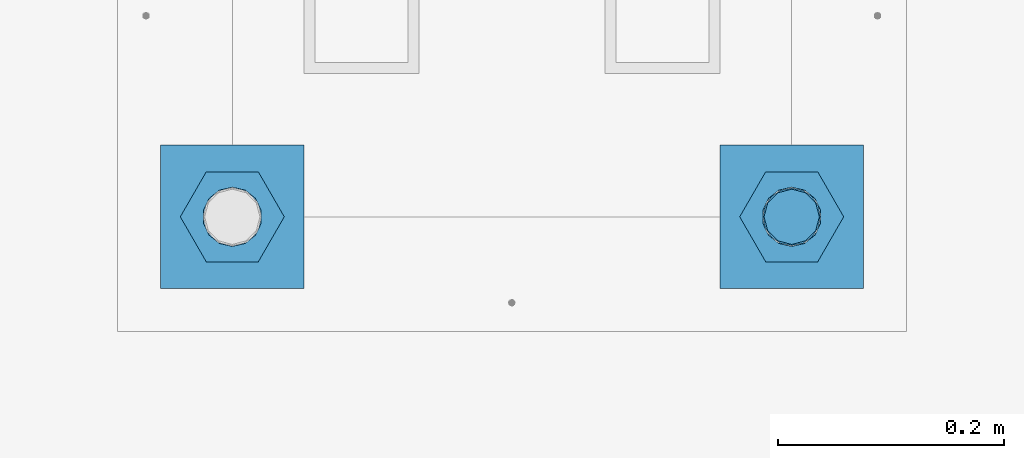
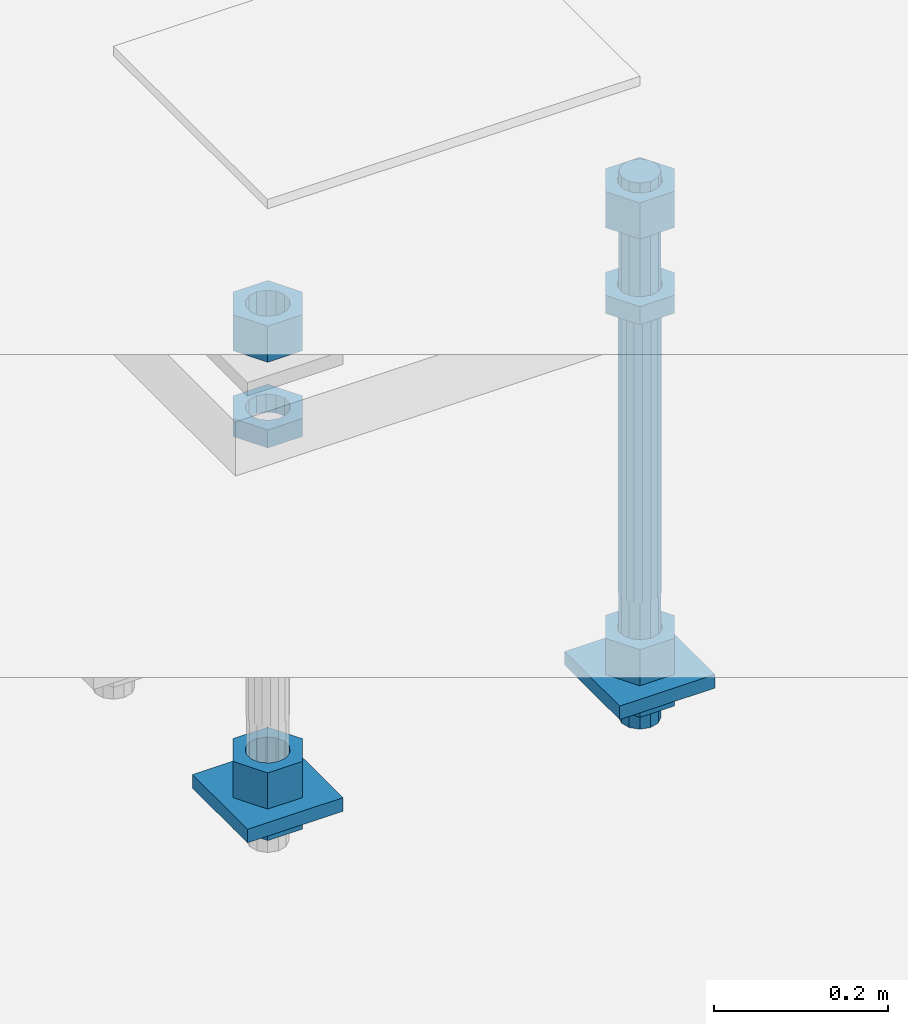
# One storey, part 2594 of 3843: 11 beams, 1 element without a shape of its own.
"""IFC2X3 building model written with IfcOpenShell, lengths in millimetres."""

from ifc_helpers import new_model, si_unit, frame, origin_with_axes, place, context, subcontext, project, spatial, faceted_brep, material, type_object, element, aggregate, save


model = new_model("IFC2X3")

# Units and contexts
model_context = context("Model", 3, precision=1e-05, world=origin_with_axes())
body_context = subcontext(model_context, "Body", "Model", "MODEL_VIEW")
ifc_project = project(units=[si_unit("LENGTHUNIT", "METRE", prefix="MILLI"), si_unit("AREAUNIT", "SQUARE_METRE"), si_unit("VOLUMEUNIT", "CUBIC_METRE"), si_unit("MASSUNIT", "GRAM", prefix="KILO"), si_unit("TIMEUNIT", "SECOND"), si_unit("PLANEANGLEUNIT", "RADIAN"), si_unit("SOLIDANGLEUNIT", "STERADIAN"), si_unit("THERMODYNAMICTEMPERATUREUNIT", "DEGREE_CELSIUS"), si_unit("LUMINOUSINTENSITYUNIT", "LUMEN")], contexts=[model_context])

# Site, building, storey
site_placement = place(None, origin_with_axes())
site = spatial("IfcSite", under=ifc_project, at=site_placement, CompositionType="ELEMENT")
building_placement = place(site_placement, origin_with_axes())
building = spatial("IfcBuilding", under=site, at=building_placement, Name="Undefined", CompositionType="ELEMENT")
storey_placement = place(building_placement, origin_with_axes())
storey = spatial("IfcBuildingStorey", under=building, at=storey_placement, Name="Undefined", CompositionType="ELEMENT", Elevation=0.0)

# Assembly, beams
assembly_placement = place(storey_placement, origin_with_axes())
assembly = element("IfcElementAssembly", 1, at=assembly_placement, inside=storey, Name="TEMPLATE", AssemblyPlace="NOTDEFINED", PredefinedType="RIGID_FRAME")
ifc_material_1 = material(Name="STEEL/A572-50")
beam_type_1 = type_object("IfcBeamType", PredefinedType="NOTDEFINED")
beam_1_placement = place(assembly_placement, frame((105403.65, 17602.1999984741, 29244.925), z_axis=(-1.0, 0.0, 0.0), x_axis=(0.0, -1.0, 0.0)))
beam_1 = element("IfcBeam", 2, at=beam_1_placement, type_object=beam_type_1, material=ifc_material_1, Name="WASHER_PLATE", context=body_context, shape_type="Brep", body=[
    faceted_brep([(0.0, 9.52500000000146, -63.5), (0.0, 9.52500000000146, 63.5), (127.0, 9.52500000000146, 63.5), (127.0, 9.52500000000146, -63.5), (0.0, -9.52500000000146, 63.5), (127.0, -9.52500000000146, 63.5), (0.0, -9.52500000000146, -63.5), (127.0, -9.52500000000146, -63.5)], [[[0, 1, 2, 3]], [[1, 4, 5, 2]], [[4, 6, 7, 5]], [[6, 0, 3, 7]], [[5, 7, 3, 2]], [[6, 4, 1, 0]]]),
])
beam_2_placement = place(assembly_placement, frame((104908.35, 17602.1999984741, 29244.925), z_axis=(-1.0, 0.0, 0.0), x_axis=(0.0, -1.0, 0.0)))
beam_2 = element("IfcBeam", 3, at=beam_2_placement, type_object=beam_type_1, material=ifc_material_1, Name="WASHER_PLATE", context=body_context, shape_type="Brep", body=[
    faceted_brep([(0.0, 9.52500000000146, -63.5), (0.0, 9.52500000000146, 63.5), (127.0, 9.52500000000146, 63.5), (127.0, 9.52500000000146, -63.5), (0.0, -9.52500000000146, 63.5), (127.0, -9.52500000000146, 63.5), (0.0, -9.52500000000146, -63.5), (127.0, -9.52500000000146, -63.5)], [[[0, 1, 2, 3]], [[1, 4, 5, 2]], [[4, 6, 7, 5]], [[6, 0, 3, 7]], [[5, 7, 3, 2]], [[6, 4, 1, 0]]]),
])
ifc_material_2 = material(Name="STEEL/A36")
beam_type_2 = type_object("IfcBeamType", Name="2_HALF_NUT", PredefinedType="NOTDEFINED")
beam_3_placement = place(assembly_placement, frame((105403.65, 17538.6999984741, 29787.85), z_axis=(0.0, -1.0, 0.0), x_axis=(0.0, 0.0, -1.0)))
beam_3 = element("IfcBeam", 4, at=beam_3_placement, type_object=beam_type_2, material=ifc_material_2, Name="NUT", ObjectType="2_HALF_NUT", context=body_context, shape_type="Brep", body=[
    faceted_brep([(0.0, -46.0369987487793, 0.0), (0.0, -23.0184993743896, -39.869213104248), (25.4000000000015, -23.0184993743896, -39.869213104248), (25.4000000000015, -46.0369987487793, 0.0), (0.0, 23.0184993743896, -39.869213104248), (25.4000000000015, 23.0184993743896, -39.869213104248), (0.0, 46.0369987487793, 0.0), (25.4000000000015, 46.0369987487793, 0.0), (0.0, 23.0184993743896, 39.869213104248), (25.4000000000015, 23.0184993743896, 39.869213104248), (0.0, -23.0184993743896, 39.869213104248), (25.4000000000015, -23.0184993743896, 39.869213104248), (0.0, 0.0, 26.1940002441406), (0.0, 11.3650617044477, 23.5999013092805), (25.4000000000015, 11.3650617044477, 23.5999013092805), (25.4000000000015, 0.0, 26.1940002441406), (0.0, 20.4791109456419, 16.3316083006721), (25.4000000000015, 20.4791109456419, 16.3316083006721), (0.0, 25.5370200498292, 5.82867859874386), (25.4000000000015, 25.5370200498292, 5.82867859874386), (0.0, 25.5370200498292, -5.82867859874386), (25.4000000000015, 25.5370200498292, -5.82867859874386), (0.0, 20.4791109456419, -16.3316083006721), (25.4000000000015, 20.4791109456419, -16.3316083006721), (0.0, 11.3650617044477, -23.5999013092805), (25.4000000000015, 11.3650617044477, -23.5999013092805), (0.0, 0.0, -26.1940002441406), (25.4000000000015, 0.0, -26.1940002441406), (0.0, -11.3650617044477, -23.5999013092805), (25.4000000000015, -11.3650617044477, -23.5999013092805), (0.0, -20.4791109456419, -16.3316083006721), (25.4000000000015, -20.4791109456419, -16.3316083006721), (0.0, -25.5370200498292, -5.82867859874386), (25.4000000000015, -25.5370200498292, -5.82867859874386), (0.0, -25.5370200498292, 5.82867859874386), (25.4000000000015, -25.5370200498292, 5.82867859874386), (0.0, -20.4791109456419, 16.3316083006721), (25.4000000000015, -20.4791109456419, 16.3316083006721), (0.0, -11.3650617044477, 23.5999013092805), (25.4000000000015, -11.3650617044477, 23.5999013092805)], [[[0, 1, 2, 3]], [[1, 4, 5, 2]], [[4, 6, 7, 5]], [[6, 8, 9, 7]], [[8, 10, 11, 9]], [[10, 0, 3, 11]], [[12, 13, 14, 15]], [[13, 16, 17, 14]], [[16, 18, 19, 17]], [[18, 20, 21, 19]], [[20, 22, 23, 21]], [[22, 24, 25, 23]], [[24, 26, 27, 25]], [[26, 28, 29, 27]], [[28, 30, 31, 29]], [[30, 32, 33, 31]], [[32, 34, 35, 33]], [[34, 36, 37, 35]], [[36, 38, 39, 37]], [[38, 12, 15, 39]], [[5, 7, 9, 11, 3, 2], [17, 19, 21, 23, 25, 27, 29, 31, 33, 35, 37, 39, 15, 14]], [[10, 8, 6, 4, 1, 0], [38, 36, 34, 32, 30, 28, 26, 24, 22, 20, 18, 16, 13, 12]]]),
])
beam_4_placement = place(assembly_placement, frame((105403.65, 17538.6999984741, 29235.4), z_axis=(0.0, -1.0, 0.0), x_axis=(0.0, 0.0, -1.0)))
beam_4 = element("IfcBeam", 5, at=beam_4_placement, type_object=beam_type_2, material=ifc_material_2, Name="NUT", ObjectType="2_HALF_NUT", context=body_context, shape_type="Brep", body=[
    faceted_brep([(0.0, -46.0369987487793, 0.0), (0.0, -23.0184993743896, -39.869213104248), (25.4000000000015, -23.0184993743896, -39.869213104248), (25.4000000000015, -46.0369987487793, 0.0), (0.0, 23.0184993743896, -39.869213104248), (25.4000000000015, 23.0184993743896, -39.869213104248), (0.0, 46.0369987487793, 0.0), (25.4000000000015, 46.0369987487793, 0.0), (0.0, 23.0184993743896, 39.869213104248), (25.4000000000015, 23.0184993743896, 39.869213104248), (0.0, -23.0184993743896, 39.869213104248), (25.4000000000015, -23.0184993743896, 39.869213104248), (0.0, 0.0, 26.1940002441406), (0.0, 11.3650617044477, 23.5999013092805), (25.4000000000015, 11.3650617044477, 23.5999013092805), (25.4000000000015, 0.0, 26.1940002441406), (0.0, 20.4791109456419, 16.3316083006721), (25.4000000000015, 20.4791109456419, 16.3316083006721), (0.0, 25.5370200498292, 5.82867859874386), (25.4000000000015, 25.5370200498292, 5.82867859874386), (0.0, 25.5370200498292, -5.82867859874386), (25.4000000000015, 25.5370200498292, -5.82867859874386), (0.0, 20.4791109456419, -16.3316083006721), (25.4000000000015, 20.4791109456419, -16.3316083006721), (0.0, 11.3650617044477, -23.5999013092805), (25.4000000000015, 11.3650617044477, -23.5999013092805), (0.0, 0.0, -26.1940002441406), (25.4000000000015, 0.0, -26.1940002441406), (0.0, -11.3650617044477, -23.5999013092805), (25.4000000000015, -11.3650617044477, -23.5999013092805), (0.0, -20.4791109456419, -16.3316083006721), (25.4000000000015, -20.4791109456419, -16.3316083006721), (0.0, -25.5370200498292, -5.82867859874386), (25.4000000000015, -25.5370200498292, -5.82867859874386), (0.0, -25.5370200498292, 5.82867859874386), (25.4000000000015, -25.5370200498292, 5.82867859874386), (0.0, -20.4791109456419, 16.3316083006721), (25.4000000000015, -20.4791109456419, 16.3316083006721), (0.0, -11.3650617044477, 23.5999013092805), (25.4000000000015, -11.3650617044477, 23.5999013092805)], [[[0, 1, 2, 3]], [[1, 4, 5, 2]], [[4, 6, 7, 5]], [[6, 8, 9, 7]], [[8, 10, 11, 9]], [[10, 0, 3, 11]], [[12, 13, 14, 15]], [[13, 16, 17, 14]], [[16, 18, 19, 17]], [[18, 20, 21, 19]], [[20, 22, 23, 21]], [[22, 24, 25, 23]], [[24, 26, 27, 25]], [[26, 28, 29, 27]], [[28, 30, 31, 29]], [[30, 32, 33, 31]], [[32, 34, 35, 33]], [[34, 36, 37, 35]], [[36, 38, 39, 37]], [[38, 12, 15, 39]], [[5, 7, 9, 11, 3, 2], [17, 19, 21, 23, 25, 27, 29, 31, 33, 35, 37, 39, 15, 14]], [[10, 8, 6, 4, 1, 0], [38, 36, 34, 32, 30, 28, 26, 24, 22, 20, 18, 16, 13, 12]]]),
])
beam_5_placement = place(assembly_placement, frame((104908.35, 17538.6999984741, 29787.85), z_axis=(0.0, -1.0, 0.0), x_axis=(0.0, 0.0, -1.0)))
beam_5 = element("IfcBeam", 6, at=beam_5_placement, type_object=beam_type_2, material=ifc_material_2, Name="NUT", ObjectType="2_HALF_NUT", context=body_context, shape_type="Brep", body=[
    faceted_brep([(0.0, -46.0369987487793, 0.0), (0.0, -23.0184993743896, -39.869213104248), (25.4000000000015, -23.0184993743896, -39.869213104248), (25.4000000000015, -46.0369987487793, 0.0), (0.0, 23.0184993743896, -39.869213104248), (25.4000000000015, 23.0184993743896, -39.869213104248), (0.0, 46.0369987487793, 0.0), (25.4000000000015, 46.0369987487793, 0.0), (0.0, 23.0184993743896, 39.869213104248), (25.4000000000015, 23.0184993743896, 39.869213104248), (0.0, -23.0184993743896, 39.869213104248), (25.4000000000015, -23.0184993743896, 39.869213104248), (0.0, 0.0, 26.1940002441406), (0.0, 11.3650617044477, 23.5999013092805), (25.4000000000015, 11.3650617044477, 23.5999013092805), (25.4000000000015, 0.0, 26.1940002441406), (0.0, 20.4791109456419, 16.3316083006721), (25.4000000000015, 20.4791109456419, 16.3316083006721), (0.0, 25.5370200498292, 5.82867859874386), (25.4000000000015, 25.5370200498292, 5.82867859874386), (0.0, 25.5370200498292, -5.82867859874386), (25.4000000000015, 25.5370200498292, -5.82867859874386), (0.0, 20.4791109456419, -16.3316083006721), (25.4000000000015, 20.4791109456419, -16.3316083006721), (0.0, 11.3650617044477, -23.5999013092805), (25.4000000000015, 11.3650617044477, -23.5999013092805), (0.0, 0.0, -26.1940002441406), (25.4000000000015, 0.0, -26.1940002441406), (0.0, -11.3650617044477, -23.5999013092805), (25.4000000000015, -11.3650617044477, -23.5999013092805), (0.0, -20.4791109456419, -16.3316083006721), (25.4000000000015, -20.4791109456419, -16.3316083006721), (0.0, -25.5370200498292, -5.82867859874386), (25.4000000000015, -25.5370200498292, -5.82867859874386), (0.0, -25.5370200498292, 5.82867859874386), (25.4000000000015, -25.5370200498292, 5.82867859874386), (0.0, -20.4791109456419, 16.3316083006721), (25.4000000000015, -20.4791109456419, 16.3316083006721), (0.0, -11.3650617044477, 23.5999013092805), (25.4000000000015, -11.3650617044477, 23.5999013092805)], [[[0, 1, 2, 3]], [[1, 4, 5, 2]], [[4, 6, 7, 5]], [[6, 8, 9, 7]], [[8, 10, 11, 9]], [[10, 0, 3, 11]], [[12, 13, 14, 15]], [[13, 16, 17, 14]], [[16, 18, 19, 17]], [[18, 20, 21, 19]], [[20, 22, 23, 21]], [[22, 24, 25, 23]], [[24, 26, 27, 25]], [[26, 28, 29, 27]], [[28, 30, 31, 29]], [[30, 32, 33, 31]], [[32, 34, 35, 33]], [[34, 36, 37, 35]], [[36, 38, 39, 37]], [[38, 12, 15, 39]], [[5, 7, 9, 11, 3, 2], [17, 19, 21, 23, 25, 27, 29, 31, 33, 35, 37, 39, 15, 14]], [[10, 8, 6, 4, 1, 0], [38, 36, 34, 32, 30, 28, 26, 24, 22, 20, 18, 16, 13, 12]]]),
])
beam_6_placement = place(assembly_placement, frame((104908.35, 17538.6999984741, 29235.4), z_axis=(0.0, -1.0, 0.0), x_axis=(0.0, 0.0, -1.0)))
beam_6 = element("IfcBeam", 7, at=beam_6_placement, type_object=beam_type_2, material=ifc_material_2, Name="NUT", ObjectType="2_HALF_NUT", context=body_context, shape_type="Brep", body=[
    faceted_brep([(0.0, -46.0369987487793, 0.0), (0.0, -23.0184993743896, -39.869213104248), (25.4000000000015, -23.0184993743896, -39.869213104248), (25.4000000000015, -46.0369987487793, 0.0), (0.0, 23.0184993743896, -39.869213104248), (25.4000000000015, 23.0184993743896, -39.869213104248), (0.0, 46.0369987487793, 0.0), (25.4000000000015, 46.0369987487793, 0.0), (0.0, 23.0184993743896, 39.869213104248), (25.4000000000015, 23.0184993743896, 39.869213104248), (0.0, -23.0184993743896, 39.869213104248), (25.4000000000015, -23.0184993743896, 39.869213104248), (0.0, 0.0, 26.1940002441406), (0.0, 11.3650617044477, 23.5999013092805), (25.4000000000015, 11.3650617044477, 23.5999013092805), (25.4000000000015, 0.0, 26.1940002441406), (0.0, 20.4791109456419, 16.3316083006721), (25.4000000000015, 20.4791109456419, 16.3316083006721), (0.0, 25.5370200498292, 5.82867859874386), (25.4000000000015, 25.5370200498292, 5.82867859874386), (0.0, 25.5370200498292, -5.82867859874386), (25.4000000000015, 25.5370200498292, -5.82867859874386), (0.0, 20.4791109456419, -16.3316083006721), (25.4000000000015, 20.4791109456419, -16.3316083006721), (0.0, 11.3650617044477, -23.5999013092805), (25.4000000000015, 11.3650617044477, -23.5999013092805), (0.0, 0.0, -26.1940002441406), (25.4000000000015, 0.0, -26.1940002441406), (0.0, -11.3650617044477, -23.5999013092805), (25.4000000000015, -11.3650617044477, -23.5999013092805), (0.0, -20.4791109456419, -16.3316083006721), (25.4000000000015, -20.4791109456419, -16.3316083006721), (0.0, -25.5370200498292, -5.82867859874386), (25.4000000000015, -25.5370200498292, -5.82867859874386), (0.0, -25.5370200498292, 5.82867859874386), (25.4000000000015, -25.5370200498292, 5.82867859874386), (0.0, -20.4791109456419, 16.3316083006721), (25.4000000000015, -20.4791109456419, 16.3316083006721), (0.0, -11.3650617044477, 23.5999013092805), (25.4000000000015, -11.3650617044477, 23.5999013092805)], [[[0, 1, 2, 3]], [[1, 4, 5, 2]], [[4, 6, 7, 5]], [[6, 8, 9, 7]], [[8, 10, 11, 9]], [[10, 0, 3, 11]], [[12, 13, 14, 15]], [[13, 16, 17, 14]], [[16, 18, 19, 17]], [[18, 20, 21, 19]], [[20, 22, 23, 21]], [[22, 24, 25, 23]], [[24, 26, 27, 25]], [[26, 28, 29, 27]], [[28, 30, 31, 29]], [[30, 32, 33, 31]], [[32, 34, 35, 33]], [[34, 36, 37, 35]], [[36, 38, 39, 37]], [[38, 12, 15, 39]], [[5, 7, 9, 11, 3, 2], [17, 19, 21, 23, 25, 27, 29, 31, 33, 35, 37, 39, 15, 14]], [[10, 8, 6, 4, 1, 0], [38, 36, 34, 32, 30, 28, 26, 24, 22, 20, 18, 16, 13, 12]]]),
])
beam_type_3 = type_object("IfcBeamType", Name="2_HEAVY_HEX_NUT", PredefinedType="NOTDEFINED")
beam_7_placement = place(assembly_placement, frame((105403.65, 17538.6999984741, 29933.9), z_axis=(0.0, -1.0, 0.0), x_axis=(0.0, 0.0, -1.0)))
beam_7 = element("IfcBeam", 8, at=beam_7_placement, type_object=beam_type_3, material=ifc_material_2, Name="NUT", ObjectType="2_HEAVY_HEX_NUT", context=body_context, shape_type="Brep", body=[
    faceted_brep([(0.0, -46.0369987487793, 0.0), (0.0, -23.0184993743896, -39.869213104248), (50.7999999999993, -23.0184993743896, -39.869213104248), (50.7999999999993, -46.0369987487793, 0.0), (0.0, 23.0184993743896, -39.869213104248), (50.7999999999993, 23.0184993743896, -39.869213104248), (0.0, 46.0369987487793, 0.0), (50.7999999999993, 46.0369987487793, 0.0), (0.0, 23.0184993743896, 39.869213104248), (50.7999999999993, 23.0184993743896, 39.869213104248), (0.0, -23.0184993743896, 39.869213104248), (50.7999999999993, -23.0184993743896, 39.869213104248), (0.0, 0.0, 26.1940002441406), (0.0, 11.3650617044477, 23.5999013092805), (50.7999999999993, 11.3650617044477, 23.5999013092805), (50.7999999999993, 0.0, 26.1940002441406), (0.0, 20.4791109456419, 16.3316083006721), (50.7999999999993, 20.4791109456419, 16.3316083006721), (0.0, 25.5370200498292, 5.82867859874386), (50.7999999999993, 25.5370200498292, 5.82867859874386), (0.0, 25.5370200498292, -5.82867859874386), (50.7999999999993, 25.5370200498292, -5.82867859874386), (0.0, 20.4791109456419, -16.3316083006721), (50.7999999999993, 20.4791109456419, -16.3316083006721), (0.0, 11.3650617044477, -23.5999013092805), (50.7999999999993, 11.3650617044477, -23.5999013092805), (0.0, 0.0, -26.1940002441406), (50.7999999999993, 0.0, -26.1940002441406), (0.0, -11.3650617044477, -23.5999013092805), (50.7999999999993, -11.3650617044477, -23.5999013092805), (0.0, -20.4791109456419, -16.3316083006721), (50.7999999999993, -20.4791109456419, -16.3316083006721), (0.0, -25.5370200498292, -5.82867859874386), (50.7999999999993, -25.5370200498292, -5.82867859874386), (0.0, -25.5370200498292, 5.82867859874386), (50.7999999999993, -25.5370200498292, 5.82867859874386), (0.0, -20.4791109456419, 16.3316083006721), (50.7999999999993, -20.4791109456419, 16.3316083006721), (0.0, -11.3650617044477, 23.5999013092805), (50.7999999999993, -11.3650617044477, 23.5999013092805)], [[[0, 1, 2, 3]], [[1, 4, 5, 2]], [[4, 6, 7, 5]], [[6, 8, 9, 7]], [[8, 10, 11, 9]], [[10, 0, 3, 11]], [[12, 13, 14, 15]], [[13, 16, 17, 14]], [[16, 18, 19, 17]], [[18, 20, 21, 19]], [[20, 22, 23, 21]], [[22, 24, 25, 23]], [[24, 26, 27, 25]], [[26, 28, 29, 27]], [[28, 30, 31, 29]], [[30, 32, 33, 31]], [[32, 34, 35, 33]], [[34, 36, 37, 35]], [[36, 38, 39, 37]], [[38, 12, 15, 39]], [[5, 7, 9, 11, 3, 2], [17, 19, 21, 23, 25, 27, 29, 31, 33, 35, 37, 39, 15, 14]], [[10, 8, 6, 4, 1, 0], [38, 36, 34, 32, 30, 28, 26, 24, 22, 20, 18, 16, 13, 12]]]),
])
beam_8_placement = place(assembly_placement, frame((105403.65, 17538.6999984741, 29305.25), z_axis=(0.0, -1.0, 0.0), x_axis=(0.0, 0.0, -1.0)))
beam_8 = element("IfcBeam", 9, at=beam_8_placement, type_object=beam_type_3, material=ifc_material_2, Name="NUT", ObjectType="2_HEAVY_HEX_NUT", context=body_context, shape_type="Brep", body=[
    faceted_brep([(0.0, -46.0369987487793, 0.0), (0.0, -23.0184993743896, -39.869213104248), (50.7999999999993, -23.0184993743896, -39.869213104248), (50.7999999999993, -46.0369987487793, 0.0), (0.0, 23.0184993743896, -39.869213104248), (50.7999999999993, 23.0184993743896, -39.869213104248), (0.0, 46.0369987487793, 0.0), (50.7999999999993, 46.0369987487793, 0.0), (0.0, 23.0184993743896, 39.869213104248), (50.7999999999993, 23.0184993743896, 39.869213104248), (0.0, -23.0184993743896, 39.869213104248), (50.7999999999993, -23.0184993743896, 39.869213104248), (0.0, 0.0, 26.1940002441406), (0.0, 11.3650617044477, 23.5999013092805), (50.7999999999993, 11.3650617044477, 23.5999013092805), (50.7999999999993, 0.0, 26.1940002441406), (0.0, 20.4791109456419, 16.3316083006721), (50.7999999999993, 20.4791109456419, 16.3316083006721), (0.0, 25.5370200498292, 5.82867859874386), (50.7999999999993, 25.5370200498292, 5.82867859874386), (0.0, 25.5370200498292, -5.82867859874386), (50.7999999999993, 25.5370200498292, -5.82867859874386), (0.0, 20.4791109456419, -16.3316083006721), (50.7999999999993, 20.4791109456419, -16.3316083006721), (0.0, 11.3650617044477, -23.5999013092805), (50.7999999999993, 11.3650617044477, -23.5999013092805), (0.0, 0.0, -26.1940002441406), (50.7999999999993, 0.0, -26.1940002441406), (0.0, -11.3650617044477, -23.5999013092805), (50.7999999999993, -11.3650617044477, -23.5999013092805), (0.0, -20.4791109456419, -16.3316083006721), (50.7999999999993, -20.4791109456419, -16.3316083006721), (0.0, -25.5370200498292, -5.82867859874386), (50.7999999999993, -25.5370200498292, -5.82867859874386), (0.0, -25.5370200498292, 5.82867859874386), (50.7999999999993, -25.5370200498292, 5.82867859874386), (0.0, -20.4791109456419, 16.3316083006721), (50.7999999999993, -20.4791109456419, 16.3316083006721), (0.0, -11.3650617044477, 23.5999013092805), (50.7999999999993, -11.3650617044477, 23.5999013092805)], [[[0, 1, 2, 3]], [[1, 4, 5, 2]], [[4, 6, 7, 5]], [[6, 8, 9, 7]], [[8, 10, 11, 9]], [[10, 0, 3, 11]], [[12, 13, 14, 15]], [[13, 16, 17, 14]], [[16, 18, 19, 17]], [[18, 20, 21, 19]], [[20, 22, 23, 21]], [[22, 24, 25, 23]], [[24, 26, 27, 25]], [[26, 28, 29, 27]], [[28, 30, 31, 29]], [[30, 32, 33, 31]], [[32, 34, 35, 33]], [[34, 36, 37, 35]], [[36, 38, 39, 37]], [[38, 12, 15, 39]], [[5, 7, 9, 11, 3, 2], [17, 19, 21, 23, 25, 27, 29, 31, 33, 35, 37, 39, 15, 14]], [[10, 8, 6, 4, 1, 0], [38, 36, 34, 32, 30, 28, 26, 24, 22, 20, 18, 16, 13, 12]]]),
])
beam_9_placement = place(assembly_placement, frame((104908.35, 17538.6999984741, 29933.9), z_axis=(0.0, -1.0, 0.0), x_axis=(0.0, 0.0, -1.0)))
beam_9 = element("IfcBeam", 10, at=beam_9_placement, type_object=beam_type_3, material=ifc_material_2, Name="NUT", ObjectType="2_HEAVY_HEX_NUT", context=body_context, shape_type="Brep", body=[
    faceted_brep([(0.0, -46.0369987487793, 0.0), (0.0, -23.0184993743896, -39.869213104248), (50.7999999999993, -23.0184993743896, -39.869213104248), (50.7999999999993, -46.0369987487793, 0.0), (0.0, 23.0184993743896, -39.869213104248), (50.7999999999993, 23.0184993743896, -39.869213104248), (0.0, 46.0369987487793, 0.0), (50.7999999999993, 46.0369987487793, 0.0), (0.0, 23.0184993743896, 39.869213104248), (50.7999999999993, 23.0184993743896, 39.869213104248), (0.0, -23.0184993743896, 39.869213104248), (50.7999999999993, -23.0184993743896, 39.869213104248), (0.0, 0.0, 26.1940002441406), (0.0, 11.3650617044477, 23.5999013092805), (50.7999999999993, 11.3650617044477, 23.5999013092805), (50.7999999999993, 0.0, 26.1940002441406), (0.0, 20.4791109456419, 16.3316083006721), (50.7999999999993, 20.4791109456419, 16.3316083006721), (0.0, 25.5370200498292, 5.82867859874386), (50.7999999999993, 25.5370200498292, 5.82867859874386), (0.0, 25.5370200498292, -5.82867859874386), (50.7999999999993, 25.5370200498292, -5.82867859874386), (0.0, 20.4791109456419, -16.3316083006721), (50.7999999999993, 20.4791109456419, -16.3316083006721), (0.0, 11.3650617044477, -23.5999013092805), (50.7999999999993, 11.3650617044477, -23.5999013092805), (0.0, 0.0, -26.1940002441406), (50.7999999999993, 0.0, -26.1940002441406), (0.0, -11.3650617044477, -23.5999013092805), (50.7999999999993, -11.3650617044477, -23.5999013092805), (0.0, -20.4791109456419, -16.3316083006721), (50.7999999999993, -20.4791109456419, -16.3316083006721), (0.0, -25.5370200498292, -5.82867859874386), (50.7999999999993, -25.5370200498292, -5.82867859874386), (0.0, -25.5370200498292, 5.82867859874386), (50.7999999999993, -25.5370200498292, 5.82867859874386), (0.0, -20.4791109456419, 16.3316083006721), (50.7999999999993, -20.4791109456419, 16.3316083006721), (0.0, -11.3650617044477, 23.5999013092805), (50.7999999999993, -11.3650617044477, 23.5999013092805)], [[[0, 1, 2, 3]], [[1, 4, 5, 2]], [[4, 6, 7, 5]], [[6, 8, 9, 7]], [[8, 10, 11, 9]], [[10, 0, 3, 11]], [[12, 13, 14, 15]], [[13, 16, 17, 14]], [[16, 18, 19, 17]], [[18, 20, 21, 19]], [[20, 22, 23, 21]], [[22, 24, 25, 23]], [[24, 26, 27, 25]], [[26, 28, 29, 27]], [[28, 30, 31, 29]], [[30, 32, 33, 31]], [[32, 34, 35, 33]], [[34, 36, 37, 35]], [[36, 38, 39, 37]], [[38, 12, 15, 39]], [[5, 7, 9, 11, 3, 2], [17, 19, 21, 23, 25, 27, 29, 31, 33, 35, 37, 39, 15, 14]], [[10, 8, 6, 4, 1, 0], [38, 36, 34, 32, 30, 28, 26, 24, 22, 20, 18, 16, 13, 12]]]),
])
beam_10_placement = place(assembly_placement, frame((104908.35, 17538.6999984741, 29305.25), z_axis=(0.0, -1.0, 0.0), x_axis=(0.0, 0.0, -1.0)))
beam_10 = element("IfcBeam", 11, at=beam_10_placement, type_object=beam_type_3, material=ifc_material_2, Name="NUT", ObjectType="2_HEAVY_HEX_NUT", context=body_context, shape_type="Brep", body=[
    faceted_brep([(0.0, -46.0369987487793, 0.0), (0.0, -23.0184993743896, -39.869213104248), (50.7999999999993, -23.0184993743896, -39.869213104248), (50.7999999999993, -46.0369987487793, 0.0), (0.0, 23.0184993743896, -39.869213104248), (50.7999999999993, 23.0184993743896, -39.869213104248), (0.0, 46.0369987487793, 0.0), (50.7999999999993, 46.0369987487793, 0.0), (0.0, 23.0184993743896, 39.869213104248), (50.7999999999993, 23.0184993743896, 39.869213104248), (0.0, -23.0184993743896, 39.869213104248), (50.7999999999993, -23.0184993743896, 39.869213104248), (0.0, 0.0, 26.1940002441406), (0.0, 11.3650617044477, 23.5999013092805), (50.7999999999993, 11.3650617044477, 23.5999013092805), (50.7999999999993, 0.0, 26.1940002441406), (0.0, 20.4791109456419, 16.3316083006721), (50.7999999999993, 20.4791109456419, 16.3316083006721), (0.0, 25.5370200498292, 5.82867859874386), (50.7999999999993, 25.5370200498292, 5.82867859874386), (0.0, 25.5370200498292, -5.82867859874386), (50.7999999999993, 25.5370200498292, -5.82867859874386), (0.0, 20.4791109456419, -16.3316083006721), (50.7999999999993, 20.4791109456419, -16.3316083006721), (0.0, 11.3650617044477, -23.5999013092805), (50.7999999999993, 11.3650617044477, -23.5999013092805), (0.0, 0.0, -26.1940002441406), (50.7999999999993, 0.0, -26.1940002441406), (0.0, -11.3650617044477, -23.5999013092805), (50.7999999999993, -11.3650617044477, -23.5999013092805), (0.0, -20.4791109456419, -16.3316083006721), (50.7999999999993, -20.4791109456419, -16.3316083006721), (0.0, -25.5370200498292, -5.82867859874386), (50.7999999999993, -25.5370200498292, -5.82867859874386), (0.0, -25.5370200498292, 5.82867859874386), (50.7999999999993, -25.5370200498292, 5.82867859874386), (0.0, -20.4791109456419, 16.3316083006721), (50.7999999999993, -20.4791109456419, 16.3316083006721), (0.0, -11.3650617044477, 23.5999013092805), (50.7999999999993, -11.3650617044477, 23.5999013092805)], [[[0, 1, 2, 3]], [[1, 4, 5, 2]], [[4, 6, 7, 5]], [[6, 8, 9, 7]], [[8, 10, 11, 9]], [[10, 0, 3, 11]], [[12, 13, 14, 15]], [[13, 16, 17, 14]], [[16, 18, 19, 17]], [[18, 20, 21, 19]], [[20, 22, 23, 21]], [[22, 24, 25, 23]], [[24, 26, 27, 25]], [[26, 28, 29, 27]], [[28, 30, 31, 29]], [[30, 32, 33, 31]], [[32, 34, 35, 33]], [[34, 36, 37, 35]], [[36, 38, 39, 37]], [[38, 12, 15, 39]], [[5, 7, 9, 11, 3, 2], [17, 19, 21, 23, 25, 27, 29, 31, 33, 35, 37, 39, 15, 14]], [[10, 8, 6, 4, 1, 0], [38, 36, 34, 32, 30, 28, 26, 24, 22, 20, 18, 16, 13, 12]]]),
])
ifc_material_3 = material()
beam_type_4 = type_object("IfcBeamType", PredefinedType="NOTDEFINED")
beam_11_placement = place(assembly_placement, frame((105403.65, 17538.6999984741, 29762.45), z_axis=(0.0, -1.0, 0.0), x_axis=(0.0, 0.0, -1.0)))
beam_11 = element("IfcBeam", 12, at=beam_11_placement, type_object=beam_type_4, material=ifc_material_3, Name="ANCHOR_ROD", context=body_context, shape_type="Brep", body=[
    faceted_brep([(-184.150000000001, -21.217622392709, 12.25), (-184.150000000001, -12.2499999999854, 21.2176223927163), (-184.150000000001, 1.45519152283669e-11, 24.5), (-184.150000000001, 12.2500000000146, 21.2176223927163), (-184.150000000001, 21.2176223927381, 12.25), (-184.150000000001, 24.5000000000146, 0.0), (-184.150000000001, 21.2176223927381, -12.25), (-184.150000000001, 12.2500000000146, -21.2176223927163), (-184.150000000001, 1.45519152283669e-11, -24.5), (-184.150000000001, -12.2499999999854, -21.2176223927163), (-184.150000000001, -21.217622392709, -12.25), (-184.150000000001, -24.4999999999854, 0.0), (0.0, 24.5000000000146, 0.0), (0.0, 21.2176223927381, -12.25), (0.0, 12.2500000000146, -21.2176223927163), (0.0, 1.45519152283669e-11, -24.5), (0.0, -12.2499999999854, -21.2176223927163), (0.0, -21.217622392709, -12.25), (0.0, -24.4999999999854, 0.0), (0.0, -21.217622392709, 12.25), (0.0, -12.2499999999854, 21.2176223927163), (0.0, 1.45519152283669e-11, 24.5), (0.0, 12.2500000000146, 21.2176223927163), (0.0, 21.2176223927381, 12.25), (0.0, -23.4665401257807, 9.72015918207035), (0.0, -17.9605122421344, 17.9605122421417), (0.0, -9.72015918207762, 23.466540125788), (0.0, 0.0, 25.4000000000015), (0.0, 9.72015918207762, 23.466540125788), (0.0, 17.9605122421344, 17.9605122421417), (0.0, 23.4665401257807, 9.72015918207035), (0.0, 25.3999996185303, 0.0), (0.0, 23.4665401257807, -9.72015918207035), (0.0, 17.9605122421344, -17.9605122421417), (0.0, 9.72015918207762, -23.466540125788), (0.0, 0.0, -25.4000000000015), (0.0, -9.72015918207762, -23.466540125788), (0.0, -17.9605122421344, -17.9605122421417), (0.0, -23.4665401257807, -9.72015918207035), (0.0, -25.3999996185303, 0.0), (406.399999999998, -25.3999999999942, 0.0), (406.399999999998, -23.4665401257807, 9.72015918207035), (406.399999999998, -17.9605122421344, 17.9605122421417), (406.399999999998, -9.72015918207762, 23.466540125788), (406.399999999998, 0.0, 25.4000000000015), (406.399999999998, 9.72015918207762, 23.466540125788), (406.399999999998, 17.9605122421344, 17.9605122421417), (406.399999999998, 23.4665401257807, 9.72015918207035), (406.399999999998, 25.3999999999942, 0.0), (406.399999999998, 23.4665401257807, -9.72015918207035), (406.399999999998, 17.9605122421344, -17.9605122421417), (406.399999999998, 9.72015918207762, -23.466540125788), (406.399999999998, 0.0, -25.4000000000015), (406.399999999998, -9.72015918207762, -23.466540125788), (406.399999999998, -17.9605122421344, -17.9605122421417), (406.399999999998, -23.4665401257807, -9.72015918207035), (406.399999999998, -12.2499999999854, 21.2176223927163), (406.399999999998, 1.45519152283669e-11, 24.5), (406.399999999998, 12.2500000000146, 21.2176223927163), (406.399999999998, 21.2176223927381, 12.25), (406.399999999998, 24.5000000000146, 0.0), (406.399999999998, 21.2176223927381, -12.25), (406.399999999998, 12.2500000000146, -21.2176223927163), (406.399999999998, 1.45519152283669e-11, -24.5), (406.399999999998, -12.2499999999854, -21.2176223927163), (406.399999999998, -21.217622392709, -12.25), (406.399999999998, -24.4999999999854, 0.0), (406.399999999998, -21.217622392709, 12.25), (584.200000000001, -12.2499999999854, -21.2176223927163), (584.200000000001, 1.45519152283669e-11, -24.5), (584.200000000001, 12.2500000000146, -21.2176223927163), (584.200000000001, 21.2176223927381, -12.25), (584.200000000001, 24.5000000000146, 0.0), (584.200000000001, 21.2176223927381, 12.25), (584.200000000001, 12.2500000000146, 21.2176223927163), (584.200000000001, 1.45519152283669e-11, 24.5), (584.200000000001, -12.2499999999854, 21.2176223927163), (584.200000000001, -21.217622392709, 12.25), (584.200000000001, -24.4999999999854, 0.0), (584.200000000001, -21.217622392709, -12.25)], [[[0, 1, 2, 3, 4, 5, 6, 7, 8, 9, 10, 11]], [[6, 5, 12, 13]], [[7, 6, 13, 14]], [[8, 7, 14, 15]], [[9, 8, 15, 16]], [[10, 9, 16, 17]], [[11, 10, 17, 18]], [[0, 11, 18, 19]], [[1, 0, 19, 20]], [[2, 1, 20, 21]], [[3, 2, 21, 22]], [[4, 3, 22, 23]], [[5, 4, 23, 12]], [[24, 25, 26, 27, 28, 29, 30, 31, 32, 33, 34, 35, 36, 37, 38, 39], [22, 21, 20, 19, 18, 17, 16, 15, 14, 13, 12, 23]], [[24, 39, 40, 41]], [[25, 24, 41, 42]], [[26, 25, 42, 43]], [[27, 26, 43, 44]], [[28, 27, 44, 45]], [[29, 28, 45, 46]], [[30, 29, 46, 47]], [[31, 30, 47, 48]], [[32, 31, 48, 49]], [[33, 32, 49, 50]], [[34, 33, 50, 51]], [[35, 34, 51, 52]], [[36, 35, 52, 53]], [[37, 36, 53, 54]], [[38, 37, 54, 55]], [[39, 38, 55, 40]], [[54, 53, 52, 51, 50, 49, 48, 47, 46, 45, 44, 43, 42, 41, 40, 55], [56, 57, 58, 59, 60, 61, 62, 63, 64, 65, 66, 67]], [[68, 69, 70, 71, 72, 73, 74, 75, 76, 77, 78, 79]], [[76, 75, 57, 56]], [[77, 76, 56, 67]], [[78, 77, 67, 66]], [[79, 78, 66, 65]], [[68, 79, 65, 64]], [[69, 68, 64, 63]], [[70, 69, 63, 62]], [[71, 70, 62, 61]], [[72, 71, 61, 60]], [[73, 72, 60, 59]], [[74, 73, 59, 58]], [[75, 74, 58, 57]]]),
])
aggregate(assembly, [beam_3, beam_7, beam_8, beam_4, beam_1, beam_11, beam_5, beam_9, beam_10, beam_6, beam_2])

save(model, "model.ifc")
